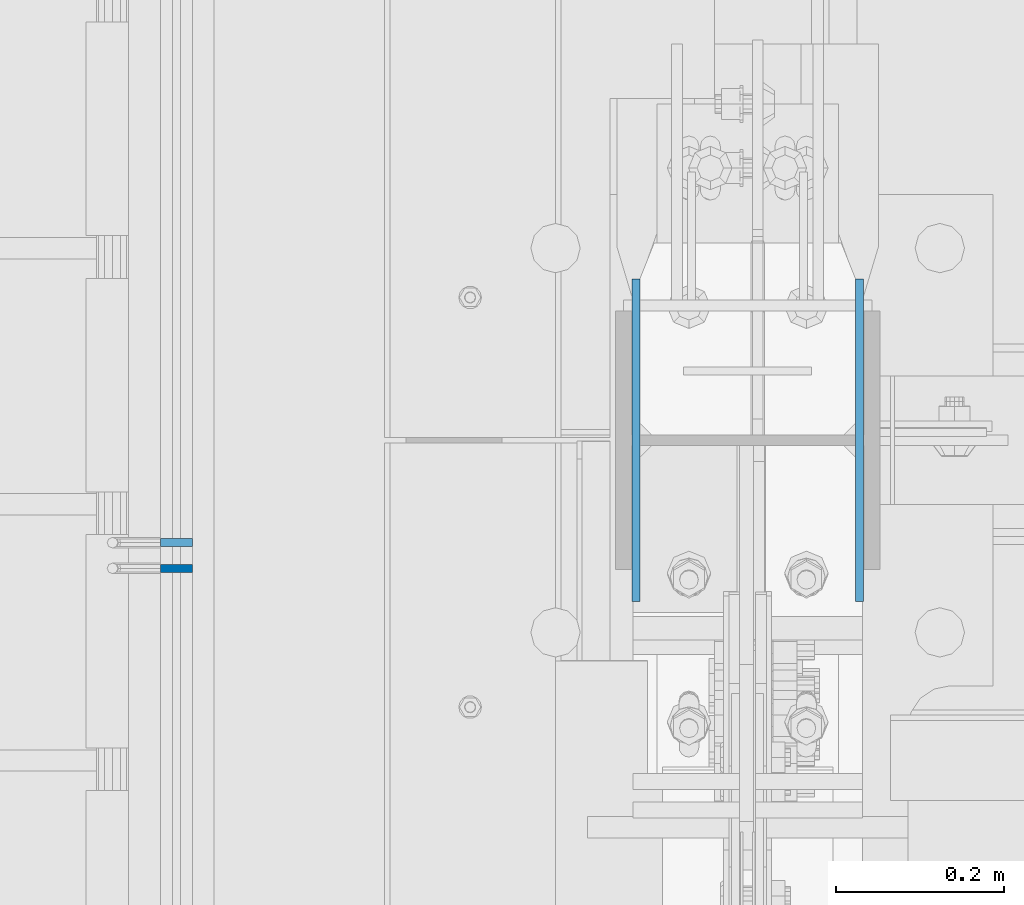
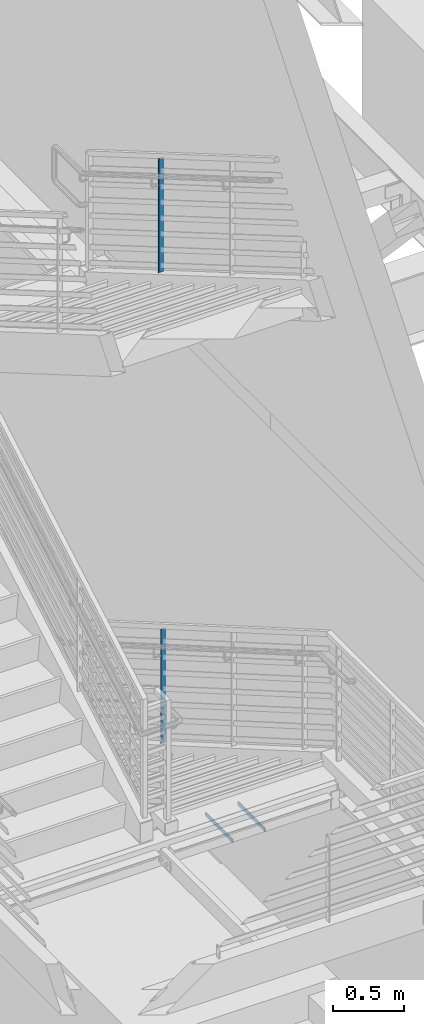
# One storey, part 488 of 1179: 4 columns, 3 elements without a shape of their own.
"""IFC2X3 building model written with IfcOpenShell, lengths in millimetres."""

from ifc_helpers import new_model, si_unit, frame, origin_with_axes, place, context, subcontext, project, spatial, faceted_brep, material, type_object, element, aggregate, save


model = new_model("IFC2X3")

# Units and contexts
model_context = context("Model", 3, precision=1e-05, world=origin_with_axes())
body_context = subcontext(model_context, "Body", "Model", "MODEL_VIEW")
ifc_project = project(units=[si_unit("LENGTHUNIT", "METRE", prefix="MILLI"), si_unit("AREAUNIT", "SQUARE_METRE"), si_unit("VOLUMEUNIT", "CUBIC_METRE"), si_unit("MASSUNIT", "GRAM", prefix="KILO"), si_unit("TIMEUNIT", "SECOND"), si_unit("PLANEANGLEUNIT", "RADIAN"), si_unit("SOLIDANGLEUNIT", "STERADIAN"), si_unit("THERMODYNAMICTEMPERATUREUNIT", "DEGREE_CELSIUS"), si_unit("LUMINOUSINTENSITYUNIT", "LUMEN")], contexts=[model_context])

# Site, building, storey
site_placement = place(None, origin_with_axes())
site = spatial("IfcSite", under=ifc_project, at=site_placement, CompositionType="ELEMENT")
building_placement = place(site_placement, origin_with_axes())
building = spatial("IfcBuilding", under=site, at=building_placement, Name="Undefined", CompositionType="ELEMENT")
storey_placement = place(building_placement, origin_with_axes())
storey = spatial("IfcBuildingStorey", under=building, at=storey_placement, Name="Undefined", CompositionType="ELEMENT", Elevation=0.0)

# Assembly, column
assembly_1_placement = place(storey_placement, origin_with_axes())
assembly_1 = element("IfcElementAssembly", 1, at=assembly_1_placement, inside=storey, Name="GUARDRAIL", AssemblyPlace="NOTDEFINED", PredefinedType="RIGID_FRAME")
ifc_material_1 = material(Name="STEEL/A36")
column_type_1 = type_object("IfcColumnType", PredefinedType="NOTDEFINED")
column_1_placement = place(assembly_1_placement, frame((-247.650000744516, 34269.6796618366, 4861.73987567253), z_axis=(-1.0, 0.0, 0.0), x_axis=(0.0, 0.0, 1.0)))
column_1 = element("IfcColumn", 2, at=column_1_placement, type_object=column_type_1, material=ifc_material_1, Name="POST", context=body_context, shape_type="Brep", body=[
    faceted_brep([(-2.77812498097046, 4.76250000000437, -19.05), (-2.77812498097046, 4.76250000000437, 19.05), (983.161981347826, 4.76249999686115, 19.05), (983.161981347826, 4.76249999686115, -19.05), (2.77812501089102, -4.76250000001164, 19.05), (988.718285375501, -4.76250000316213, 19.05), (2.77812501089102, -4.76250000001164, -19.05), (988.718285375501, -4.76250000316213, -19.05)], [[[0, 1, 2, 3]], [[1, 4, 5, 2]], [[4, 6, 7, 5]], [[6, 0, 3, 7]], [[5, 7, 3, 2]], [[6, 4, 1, 0]]]),
])
aggregate(assembly_1, [column_1])

assembly_2_placement = place(storey_placement, origin_with_axes())
assembly_2 = element("IfcElementAssembly", 3, at=assembly_2_placement, inside=storey, Name="GUARDRAIL", AssemblyPlace="NOTDEFINED", PredefinedType="RIGID_FRAME")
column_2_placement = place(assembly_2_placement, frame((-247.650000744516, 34239.2000000003, 835.148290437703), z_axis=(-1.0, 0.0, 0.0), x_axis=(0.0, 0.0, 1.0)))
column_2 = element("IfcColumn", 4, at=column_2_placement, type_object=column_type_1, material=ifc_material_1, Name="POST", context=body_context, shape_type="Brep", body=[
    faceted_brep([(-21.8075281846961, 4.76250000006985, -19.05), (-21.8075281846961, 4.76250000006985, 19.05), (964.278659810975, 4.76249999691936, 19.05), (964.278659810975, 4.76249999691936, -19.05), (-16.2924717865309, -4.76249999994616, 19.05), (969.793716202767, -4.76250000310392, 19.05), (-16.2924717865309, -4.76249999994616, -19.05), (969.793716202767, -4.76250000310392, -19.05)], [[[0, 1, 2, 3]], [[1, 4, 5, 2]], [[4, 6, 7, 5]], [[6, 0, 3, 7]], [[5, 7, 3, 2]], [[6, 4, 1, 0]]]),
])
aggregate(assembly_2, [column_2])

# Assembly, columns
assembly_3_placement = place(storey_placement, origin_with_axes())
assembly_3 = element("IfcElementAssembly", 5, at=assembly_3_placement, inside=storey, Name="COLUMN", AssemblyPlace="NOTDEFINED", PredefinedType="RIGID_FRAME")
ifc_material_2 = material(Name="STEEL/A572-GR.50")
column_type_2 = type_object("IfcColumnType", PredefinedType="NOTDEFINED")
column_3_placement = place(assembly_3_placement, frame((564.753, 34391.6, -215.9), z_axis=(0.0, -1.0, 0.0), x_axis=(0.0, 0.0, 1.0)))
column_3 = element("IfcColumn", 6, at=column_3_placement, type_object=column_type_2, material=ifc_material_2, Name="PLATE", context=body_context, shape_type="Brep", body=[
    faceted_brep([(0.0, 4.76249999999982, -192.087500000001), (0.0, 4.76249999999982, 192.0875), (31.75, 4.76249999999982, 192.0875), (31.75, 4.76249999999982, -192.087500000001), (0.0, -4.76249999999982, 192.0875), (31.75, -4.76249999999982, 192.0875), (0.0, -4.76249999999982, -192.087500000001), (31.75, -4.76249999999982, -192.087500000001)], [[[0, 1, 2, 3]], [[1, 4, 5, 2]], [[4, 6, 7, 5]], [[6, 0, 3, 7]], [[5, 7, 3, 2]], [[6, 4, 1, 0]]]),
])
column_4_placement = place(assembly_3_placement, frame((298.846874999997, 34391.6, -215.9), z_axis=(0.0, -1.0, 0.0), x_axis=(0.0, 0.0, 1.0)))
column_4 = element("IfcColumn", 7, at=column_4_placement, type_object=column_type_2, material=ifc_material_2, Name="PLATE", context=body_context, shape_type="Brep", body=[
    faceted_brep([(0.0, 4.76249999999982, -192.087500000001), (0.0, 4.76249999999982, 192.0875), (31.75, 4.76249999999982, 192.0875), (31.75, 4.76249999999982, -192.087500000001), (0.0, -4.76249999999982, 192.0875), (31.75, -4.76249999999982, 192.0875), (0.0, -4.76249999999982, -192.087500000001), (31.75, -4.76249999999982, -192.087500000001)], [[[0, 1, 2, 3]], [[1, 4, 5, 2]], [[4, 6, 7, 5]], [[6, 0, 3, 7]], [[5, 7, 3, 2]], [[6, 4, 1, 0]]]),
])
aggregate(assembly_3, [column_3, column_4])

save(model, "model.ifc")
